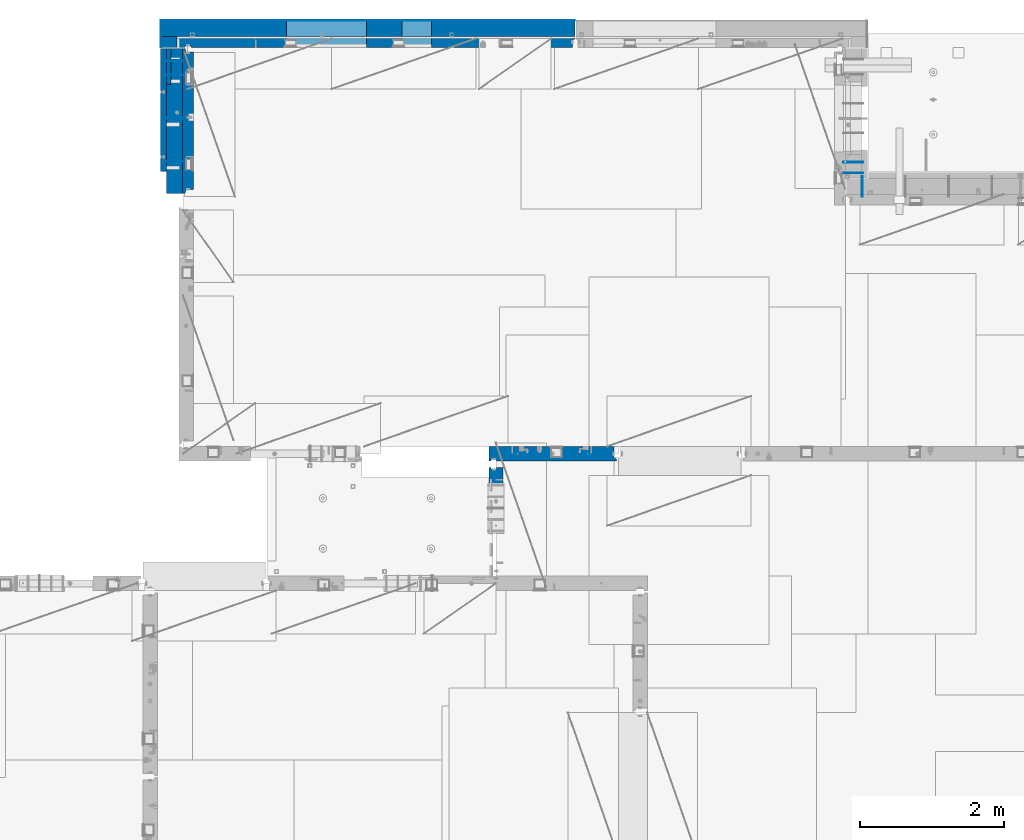
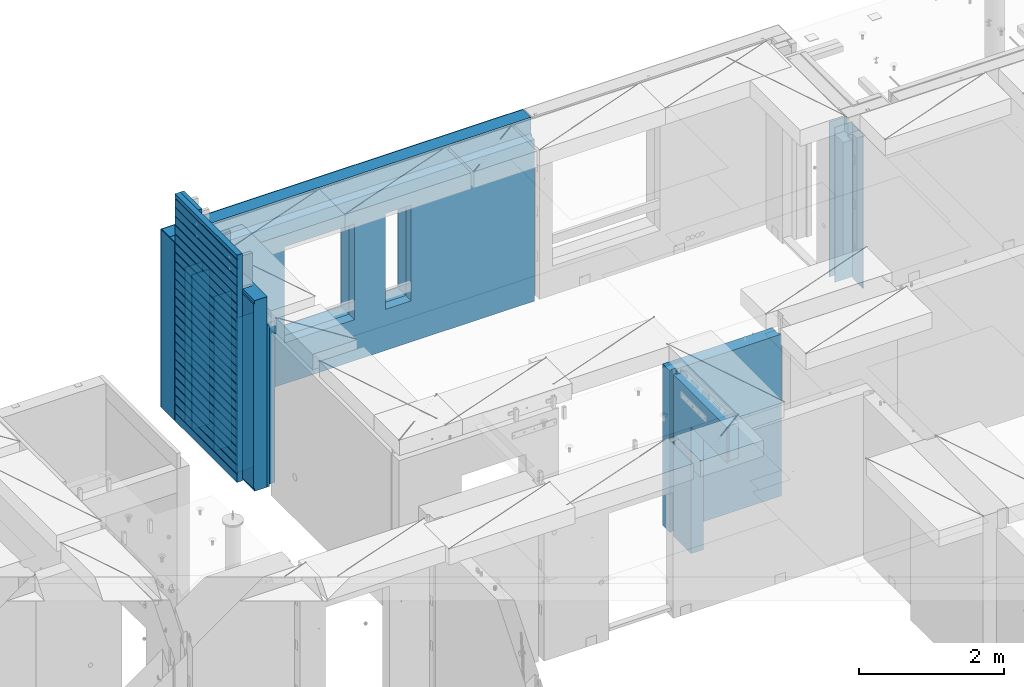
# One storey, part 204 of 309: 18 walls, 6 elements without a shape of their own.
"""IFC2X3 building model written with IfcOpenShell, lengths in millimetres."""

from ifc_helpers import new_model, si_unit, frame, origin_with_axes, place, context, subcontext, project, spatial, faceted_brep, material, type_object, element, aggregate, save


model = new_model("IFC2X3")

# Units and contexts
model_context = context("Model", 3, precision=1e-05, world=origin_with_axes())
body_context = subcontext(model_context, "Body", "Model", "MODEL_VIEW")
ifc_project = project(units=[si_unit("LENGTHUNIT", "METRE", prefix="MILLI"), si_unit("AREAUNIT", "SQUARE_METRE"), si_unit("VOLUMEUNIT", "CUBIC_METRE"), si_unit("MASSUNIT", "GRAM", prefix="KILO"), si_unit("TIMEUNIT", "SECOND"), si_unit("PLANEANGLEUNIT", "RADIAN"), si_unit("SOLIDANGLEUNIT", "STERADIAN"), si_unit("THERMODYNAMICTEMPERATUREUNIT", "DEGREE_CELSIUS"), si_unit("LUMINOUSINTENSITYUNIT", "LUMEN")], contexts=[model_context])

# Site, building, storey
site_placement = place(None, origin_with_axes())
site = spatial("IfcSite", under=ifc_project, at=site_placement, CompositionType="ELEMENT")
building_placement = place(site_placement, origin_with_axes())
building = spatial("IfcBuilding", under=site, at=building_placement, CompositionType="ELEMENT")
storey_placement = place(building_placement, origin_with_axes())
storey = spatial("IfcBuildingStorey", under=building, at=storey_placement, Name="7", CompositionType="ELEMENT", Elevation=0.0)

# Assembly, walls
assembly_1_placement = place(storey_placement, origin_with_axes())
assembly_1 = element("IfcElementAssembly", 1, at=assembly_1_placement, inside=storey, AssemblyPlace="NOTDEFINED", PredefinedType="REINFORCEMENT_UNIT")
ifc_material_1 = material(Name="Undefined")
wall_type_1 = type_object("IfcWallType", PredefinedType="NOTDEFINED")
wall_1_placement = place(assembly_1_placement, frame((22010.0, 21035.0, 101115.0), z_axis=(0.0, 0.0, 1.0), x_axis=(1.0, 0.0, 0.0)))
wall_1 = element("IfcWall", 2, at=wall_1_placement, type_object=wall_type_1, material=ifc_material_1, Name="(PD)", context=body_context, shape_type="Brep", body=[
    faceted_brep([(0.0, 5.0, -1300.0), (0.0, 5.0, 1300.0), (280.0, 5.0, 1300.0), (280.0, 5.0, -1300.0), (0.0, -5.0, 1300.0), (280.0, -5.0, 1300.0), (0.0, -5.0, -1300.0), (280.0, -5.0, -1300.0)], [[[0, 1, 2, 3]], [[1, 4, 5, 2]], [[4, 6, 7, 5]], [[6, 0, 3, 7]], [[5, 7, 3, 2]], [[6, 4, 1, 0]]]),
])
wall_2_placement = place(assembly_1_placement, frame((22010.0, 21635.0, 101115.0), z_axis=(0.0, 0.0, 1.0), x_axis=(1.0, 0.0, 0.0)))
wall_2 = element("IfcWall", 3, at=wall_2_placement, type_object=wall_type_1, material=ifc_material_1, Name="(PD)", context=body_context, shape_type="Brep", body=[
    faceted_brep([(0.0, 5.0, -1300.0), (0.0, 5.0, 1300.0), (280.0, 5.0, 1300.0), (280.0, 5.0, -1300.0), (0.0, -5.0, 1300.0), (280.0, -5.0, 1300.0), (0.0, -5.0, -1300.0), (280.0, -5.0, -1300.0)], [[[0, 1, 2, 3]], [[1, 4, 5, 2]], [[4, 6, 7, 5]], [[6, 0, 3, 7]], [[5, 7, 3, 2]], [[6, 4, 1, 0]]]),
])
wall_3_placement = place(assembly_1_placement, frame((22010.0, 22235.0, 101115.0), z_axis=(0.0, 0.0, 1.0), x_axis=(1.0, 0.0, 0.0)))
wall_3 = element("IfcWall", 4, at=wall_3_placement, type_object=wall_type_1, material=ifc_material_1, Name="(PD)", context=body_context, shape_type="Brep", body=[
    faceted_brep([(0.0, 5.0, -1300.0), (0.0, 5.0, 1300.0), (280.0, 5.0, 1300.0), (280.0, 5.0, -1300.0), (0.0, -5.0, 1300.0), (280.0, -5.0, 1300.0), (0.0, -5.0, -1300.0), (280.0, -5.0, -1300.0)], [[[0, 1, 2, 3]], [[1, 4, 5, 2]], [[4, 6, 7, 5]], [[6, 0, 3, 7]], [[5, 7, 3, 2]], [[6, 4, 1, 0]]]),
])
wall_4_placement = place(assembly_1_placement, frame((22010.0, 22435.0, 101115.0), z_axis=(0.0, 0.0, 1.0), x_axis=(1.0, 0.0, 0.0)))
wall_4 = element("IfcWall", 5, at=wall_4_placement, type_object=wall_type_1, material=ifc_material_1, Name="(PD)", context=body_context, shape_type="Brep", body=[
    faceted_brep([(0.0, 5.0, -1300.0), (0.0, 5.0, 1300.0), (280.0, 5.0, 1300.0), (280.0, 5.0, -1300.0), (0.0, -5.0, 1300.0), (280.0, -5.0, 1300.0), (0.0, -5.0, -1300.0), (280.0, -5.0, -1300.0)], [[[0, 1, 2, 3]], [[1, 4, 5, 2]], [[4, 6, 7, 5]], [[6, 0, 3, 7]], [[5, 7, 3, 2]], [[6, 4, 1, 0]]]),
])

# Assembly, wall
assembly_2_placement = place(storey_placement, origin_with_axes())
assembly_2 = element("IfcElementAssembly", 6, at=assembly_2_placement, inside=storey, AssemblyPlace="NOTDEFINED", PredefinedType="REINFORCEMENT_UNIT")
wall_5_placement = place(assembly_2_placement, frame((31695.0, 20549.9951872276, 101115.0), z_axis=(0.0, 0.0, 1.0), x_axis=(0.0, 1.0, 0.0)))
wall_5 = element("IfcWall", 7, at=wall_5_placement, type_object=wall_type_1, material=ifc_material_1, Name="(PD)", context=body_context, shape_type="Brep", body=[
    faceted_brep([(0.0, 5.0, -1300.0), (0.0, 5.0, 1300.0), (280.0, 5.0, 1300.0), (280.0, 5.0, -1300.0), (0.0, -5.0, 1300.0), (280.0, -5.0, 1300.0), (0.0, -5.0, -1300.0), (280.0, -5.0, -1300.0)], [[[0, 1, 2, 3]], [[1, 4, 5, 2]], [[4, 6, 7, 5]], [[6, 0, 3, 7]], [[5, 7, 3, 2]], [[6, 4, 1, 0]]]),
])
aggregate(assembly_2, [wall_5])

# Assembly, walls
assembly_3_placement = place(storey_placement, origin_with_axes())
assembly_3 = element("IfcElementAssembly", 8, at=assembly_3_placement, inside=storey, AssemblyPlace="NOTDEFINED", PredefinedType="REINFORCEMENT_UNIT")
wall_6_placement = place(assembly_3_placement, frame((31429.9951872276, 20875.0, 101115.0), z_axis=(0.0, 0.0, 1.0), x_axis=(1.0, 0.0, 0.0)))
wall_6 = element("IfcWall", 9, at=wall_6_placement, type_object=wall_type_1, material=ifc_material_1, Name="(PD)", context=body_context, shape_type="Brep", body=[
    faceted_brep([(0.0, 5.0, -1300.0), (0.0, 5.0, 1300.0), (280.0, 5.0, 1300.0), (280.0, 5.0, -1300.0), (0.0, -5.0, 1300.0), (280.0, -5.0, 1300.0), (0.0, -5.0, -1300.0), (280.0, -5.0, -1300.0)], [[[0, 1, 2, 3]], [[1, 4, 5, 2]], [[4, 6, 7, 5]], [[6, 0, 3, 7]], [[5, 7, 3, 2]], [[6, 4, 1, 0]]]),
])
wall_7_placement = place(assembly_3_placement, frame((31429.9951872276, 21025.0, 101115.0), z_axis=(0.0, 0.0, 1.0), x_axis=(1.0, 0.0, 0.0)))
wall_7 = element("IfcWall", 10, at=wall_7_placement, type_object=wall_type_1, material=ifc_material_1, Name="(PD)", context=body_context, shape_type="Brep", body=[
    faceted_brep([(0.0, 5.0, -1300.0), (0.0, 5.0, 1300.0), (280.0, 5.0, 1300.0), (280.0, 5.0, -1300.0), (0.0, -5.0, 1300.0), (280.0, -5.0, 1300.0), (0.0, -5.0, -1300.0), (280.0, -5.0, -1300.0)], [[[0, 1, 2, 3]], [[1, 4, 5, 2]], [[4, 6, 7, 5]], [[6, 0, 3, 7]], [[5, 7, 3, 2]], [[6, 4, 1, 0]]]),
])
aggregate(assembly_3, [wall_6, wall_7])

# Assembly, wall
assembly_4_placement = place(storey_placement, origin_with_axes())
assembly_4 = element("IfcElementAssembly", 11, at=assembly_4_placement, inside=storey, AssemblyPlace="NOTDEFINED", PredefinedType="REINFORCEMENT_UNIT")
ifc_material_2 = material(Name="CONCRETE/C25/30")
wall_type_2 = type_object("IfcWallType", PredefinedType="NOTDEFINED")
wall_8_placement = place(assembly_4_placement, frame((26510.0014364077, 16980.0, 101112.5), z_axis=(0.0, 0.0, 1.0), x_axis=(1.0, 0.0, 0.0)))
wall_8 = element("IfcWall", 12, at=wall_8_placement, type_object=wall_type_2, material=ifc_material_2, context=body_context, shape_type="Brep", body=[
    faceted_brep([(1739.99847412109, 100.0, 1357.5), (1739.99847412109, -57.0, 1357.5), (1739.99847412109, -57.0, -1357.5), (1739.99847412109, 100.0, -1357.5), (1769.99847412109, -70.0, 1357.5), (1769.99847412109, -70.0, -1357.5), (0.0, -100.0, -1357.5), (0.0, -100.0, 1357.5), (0.0, 100.0, 1357.5), (0.0, 100.0, -1357.5), (29.998563592264, -100.0, -1357.5), (29.998563592264, -100.0, 1357.5), (29.998563592264, -80.0008544921875, -1357.5), (29.998563592264, -80.0008544921875, 1357.5), (109.998563592264, -80.0008544921875, -1357.5), (109.998563592264, -80.0008544921875, 1357.5), (109.998563592264, -100.0, -1357.5), (109.998563592264, -100.0, 1357.5), (1769.99847412109, -100.0, -1357.5), (1769.99847412109, -100.0, 1357.5)], [[[0, 1, 2, 3]], [[4, 5, 2, 1]], [[6, 7, 8, 9]], [[7, 6, 10, 11]], [[11, 10, 12, 13]], [[13, 12, 14, 15]], [[15, 14, 16, 17]], [[18, 19, 17, 16]], [[0, 8, 7, 11, 13, 15, 17, 19, 4, 1]], [[9, 8, 0, 3]], [[18, 16, 14, 12, 10, 6, 9, 3, 2, 5]], [[19, 18, 5, 4]]]),
])
aggregate(assembly_4, [wall_8])

assembly_5_placement = place(storey_placement, origin_with_axes())
assembly_5 = element("IfcElementAssembly", 13, at=assembly_5_placement, inside=storey, AssemblyPlace="NOTDEFINED", PredefinedType="REINFORCEMENT_UNIT")
wall_9_placement = place(assembly_5_placement, frame((26609.9991475894, 15280.0004107749, 101112.5), z_axis=(0.0, 0.0, 1.0), x_axis=(0.0, 1.0, 0.0)))
wall_9 = element("IfcWall", 14, at=wall_9_placement, type_object=wall_type_2, material=ifc_material_2, context=body_context, shape_type="Brep", body=[
    faceted_brep([(1509.99949975397, 70.0, 1357.5), (1489.99949975397, 70.0, 1357.5), (1489.99949975397, 70.0, -1357.5), (1509.99949975397, 70.0, -1357.5), (1489.99949975397, -10.0, 1357.5), (1489.99949975397, -10.0, -1357.5), (1509.99949975397, -10.0, 1357.5), (1509.99949975397, -10.0, -1357.5), (29.9995892251427, 70.0, 1357.5), (29.9995892251427, 70.0, 762.5), (59.9995892251427, 57.0, 762.5), (59.9995892251427, 57.0, 1357.5), (29.9995892251427, 100.0, 1357.5), (29.9995892251427, 100.0, 762.5), (1509.99949975397, 100.0, 1357.5), (1509.99949975397, 100.0, -1357.5), (1019.99979369292, 100.0, -1357.5), (1019.99979369292, 100.0, 762.5), (1019.99979369292, -100.0, 762.5), (1019.99979369292, -100.0, -1357.5), (59.9995892251427, -100.0, 762.5), (59.9995892251427, -100.0, 1357.5), (1509.99949975397, -100.0, -1357.5), (1509.99949975397, -100.0, 1357.5)], [[[0, 1, 2, 3]], [[4, 5, 2, 1]], [[6, 7, 5, 4]], [[8, 9, 10, 11]], [[12, 13, 9, 8]], [[12, 14, 15, 16, 17, 13]], [[18, 17, 16, 19]], [[9, 13, 17, 18, 20, 10]], [[21, 11, 10, 20]], [[18, 19, 22, 23, 21, 20]], [[1, 0, 14, 12, 8, 11, 21, 23, 6, 4]], [[15, 14, 0, 3]], [[22, 19, 16, 15, 3, 2, 5, 7]], [[23, 22, 7, 6]]]),
])
aggregate(assembly_5, [wall_9])

# Assembly, walls
assembly_6_placement = place(storey_placement, origin_with_axes())
assembly_6 = element("IfcElementAssembly", 15, at=assembly_6_placement, inside=storey, AssemblyPlace="NOTDEFINED", PredefinedType="REINFORCEMENT_UNIT")
ifc_material_3 = material()
wall_type_3 = type_object("IfcWallType", PredefinedType="NOTDEFINED")
wall_10_placement = place(assembly_6_placement, frame((22075.0, 22620.0, 101247.5), z_axis=(0.0, 0.0, 1.0), x_axis=(0.0, 1.0, 0.0)))
wall_10 = element("IfcWall", 16, at=wall_10_placement, type_object=wall_type_3, material=ifc_material_3, context=body_context, shape_type="Brep", body=[
    faceted_brep([(0.0, 110.0, -1492.5), (0.0, 110.0, 1492.5), (150.0, 110.0, 1492.5), (150.0, 110.0, -1492.5), (0.0, -110.0, 1492.5), (150.0, -110.0, 1492.5), (0.0, -110.0, -1492.5), (150.0, -110.0, -1492.5)], [[[0, 1, 2, 3]], [[1, 4, 5, 2]], [[4, 6, 7, 5]], [[6, 0, 3, 7]], [[5, 7, 3, 2]], [[6, 4, 1, 0]]]),
])
wall_11_placement = place(assembly_6_placement, frame((22260.0, 22880.0, 101247.5), z_axis=(0.0, 0.0, 1.0), x_axis=(1.0, 0.0, 0.0)))
wall_11 = element("IfcWall", 17, at=wall_11_placement, type_object=wall_type_3, material=ifc_material_3, context=body_context, shape_type="Brep", body=[
    faceted_brep([(-295.0, 110.0, 1492.5), (-295.0, -110.0, 1492.5), (5445.0, -110.0, 1492.5), (5445.0, 110.0, 1492.5), (-295.0, -110.0, -1492.5), (-295.0, 110.0, -1492.5), (5445.0, 110.0, -1492.5), (5445.0, -110.0, -1492.5), (3044.99635379813, 110.0, -802.5), (3454.99635379813, 110.0, -802.5), (3454.99635379813, 110.0, 807.5), (3044.99635379813, 110.0, 807.5), (1444.99910133321, 110.0, -802.5), (2554.99910133321, 110.0, -802.5), (2554.99910133321, 110.0, 807.5), (1444.99910133321, 110.0, 807.5), (1444.99910133321, -110.0, -802.5), (2554.99910133321, -110.0, -802.5), (1444.99910133321, -110.0, 807.5), (2554.99910133321, -110.0, 807.5), (3044.99635379813, -110.0, -802.5), (3044.99635379813, -110.0, 807.5), (3454.99635379813, -110.0, 807.5), (3454.99635379813, -110.0, -802.5)], [[[0, 1, 2, 3]], [[4, 1, 0, 5]], [[4, 5, 6, 7]], [[2, 7, 6, 3]], [[5, 0, 3, 6], [8, 9, 10, 11], [12, 13, 14, 15]], [[12, 16, 17, 13]], [[15, 18, 16, 12]], [[14, 19, 18, 15]], [[13, 17, 19, 14]], [[1, 4, 7, 2], [20, 21, 22, 23], [16, 18, 19, 17]], [[10, 22, 21, 11]], [[9, 23, 22, 10]], [[8, 20, 23, 9]], [[11, 21, 20, 8]]]),
])
wall_type_4 = type_object("IfcWallType", PredefinedType="NOTDEFINED")
wall_12_placement = place(assembly_6_placement, frame((22192.5, 22695.0, 101112.5), z_axis=(0.0, 0.0, 1.0), x_axis=(1.0, 0.0, 0.0)))
wall_12 = element("IfcWall", 18, at=wall_12_placement, type_object=wall_type_4, material=ifc_material_2, context=body_context, shape_type="Brep", body=[
    faceted_brep([(3112.49635379813, 75.0, 942.5), (3112.49635379813, -75.0000009061441, 942.5), (3112.49635379813, -75.0000002303786, -667.5), (3112.49635379813, 75.0, -667.5), (3522.49635379813, -75.0000001420558, -667.5), (3522.49635379813, 75.0, -667.5), (3522.49635379813, -75.0000008178213, 942.5), (3522.49635379813, 75.0, 942.5), (5482.5, -75.0, 1357.5), (5482.5, -75.0, -1357.5), (5482.5, 24.9999980926514, -1357.5), (5482.5, 24.9999980926514, 1357.5), (5512.5, 45.0, 1357.5), (5512.5, 75.0, 1357.5), (0.0, 75.0, 1357.5), (0.0, -75.0, 1357.5), (92.5, -75.0, 1357.5), (102.5, -55.0000022791319, 1357.5), (182.5, -55.0000022791319, 1357.5), (192.5, -75.0000022791319, 1357.5), (0.0, -75.0, -1357.5), (0.0, 75.0, -1357.5), (92.5, -75.0, -1357.5), (102.5, -55.0000022791319, -1357.5), (182.5, -55.0000022791319, -1357.5), (192.5, -75.0, -1357.5), (5512.5, 75.0, -1357.5), (5512.5, 45.0, -1357.5), (1512.49910133321, 75.0, -667.5), (2622.49910133321, 75.0, -667.5), (2622.49910133321, 75.0, 942.5), (1512.49910133321, 75.0, 942.5), (1512.49910133321, -75.000000575048, -667.5), (2622.49910133321, -75.000000335931, -667.5), (1512.49910133321, -75.0000012508135, 942.5), (2622.49910133321, -75.0000010116964, 942.5)], [[[0, 1, 2, 3]], [[3, 2, 4, 5]], [[5, 4, 6, 7]], [[7, 6, 1, 0]], [[8, 9, 10, 11]], [[8, 11, 12, 13, 14, 15, 16, 17, 18, 19]], [[20, 15, 14, 21]], [[15, 20, 22, 16]], [[16, 22, 23, 17]], [[17, 23, 24, 18]], [[19, 18, 24, 25]], [[23, 22, 20, 21, 26, 27, 10, 9, 25, 24]], [[12, 11, 10, 27]], [[26, 13, 12, 27]], [[21, 14, 13, 26], [3, 5, 7, 0], [28, 29, 30, 31]], [[28, 32, 33, 29]], [[31, 34, 32, 28]], [[30, 35, 34, 31]], [[29, 33, 35, 30]], [[9, 8, 19, 25], [2, 1, 6, 4], [32, 34, 35, 33]]]),
])

# Wall
wall_13_placement = place(assembly_1_placement, frame((22335.0, 20595.0, 101112.5), z_axis=(0.0, 0.0, 1.0), x_axis=(0.0, 1.0, 0.0)))
wall_13 = element("IfcWall", 19, at=wall_13_placement, type_object=wall_type_4, material=ifc_material_2, context=body_context, shape_type="Brep", body=[
    faceted_brep([(0.0, 40.0, 1357.5), (0.0, 40.0, -1357.5), (50.0, 27.0, -1357.5), (50.0, 27.0, 1357.5), (50.0, -75.0, 1357.5), (50.0, -75.0, -1357.5), (0.0, 75.0, -1357.5), (0.0, 75.0, 1357.5), (2009.99999772087, 75.0, 1357.5), (2009.99999772087, 75.0, -1357.5), (2009.99999772087, 40.0, 1357.5), (2009.99999772087, 40.0, -1357.5), (1959.99999772087, 27.0, 1357.5), (1959.99999772087, 27.0, -1357.5), (1959.99999772087, -75.0, 1357.5), (1959.99999772087, -75.0, -1357.5)], [[[0, 1, 2, 3]], [[4, 3, 2, 5]], [[6, 7, 8, 9]], [[9, 8, 10, 11]], [[12, 13, 11, 10]], [[14, 15, 13, 12]], [[15, 14, 4, 5]], [[1, 6, 9, 11, 13, 15, 5, 2]], [[7, 6, 1, 0]], [[14, 12, 10, 8, 7, 0, 3, 4]]]),
])

ifc_material_4 = material(Name="CONCRETE/C30/37")
wall_type_5 = type_object("IfcWallType", PredefinedType="NOTDEFINED")
wall_14_placement = place(assembly_6_placement, frame((21960.0001313636, 22620.0, 101247.5), z_axis=(0.0, 0.0, 1.0), x_axis=(0.0, 1.0, 0.0)))
wall_14 = element("IfcWall", 20, at=wall_14_placement, type_object=wall_type_5, material=ifc_material_4, context=body_context, shape_type="Brep", body=[
    faceted_brep([(0.0, 5.0, -1492.5), (0.0, 5.0, 1492.5), (370.0, 5.0, 1492.5), (370.0, 5.0, -1492.5), (0.0, -5.0, 1492.5), (370.0, -5.0, 1492.5), (0.0, -5.0, -1492.5), (370.0, -5.0, -1492.5)], [[[0, 1, 2, 3]], [[1, 4, 5, 2]], [[4, 6, 7, 5]], [[6, 0, 3, 7]], [[5, 7, 3, 2]], [[6, 4, 1, 0]]]),
])

wall_15_placement = place(assembly_6_placement, frame((22260.0, 22995.0, 101247.5), z_axis=(0.0, 0.0, 1.0), x_axis=(1.0, 0.0, 0.0)))
wall_15 = element("IfcWall", 21, at=wall_15_placement, type_object=wall_type_5, material=ifc_material_4, context=body_context, shape_type="Brep", body=[
    faceted_brep([(-305.0, 5.0, 1492.5), (-305.0, -5.0, 1492.5), (5445.0, -5.0, 1492.5), (5445.0, 5.0, 1492.5), (-305.0, -5.0, -1492.5), (-305.0, 5.0, -1492.5), (5445.0, 5.0, -1492.5), (5445.0, -5.0, -1492.5), (3044.99635379813, 5.0, -802.5), (3454.99635379813, 5.0, -802.5), (3454.99635379813, 5.0, 807.5), (3044.99635379813, 5.0, 807.5), (1444.99910133321, 5.0, -802.5), (2554.99910133321, 5.0, -802.5), (2554.99910133321, 5.0, 807.5), (1444.99910133321, 5.0, 807.5), (1444.99910133321, -5.0, -802.5), (2554.99910133321, -5.0, -802.5), (1444.99910133321, -5.0, 807.5), (2554.99910133321, -5.0, 807.5), (3044.99635379813, -5.0, -802.5), (3044.99635379813, -5.0, 807.5), (3454.99635379813, -5.0, 807.5), (3454.99635379813, -5.0, -802.5)], [[[0, 1, 2, 3]], [[4, 1, 0, 5]], [[4, 5, 6, 7]], [[2, 7, 6, 3]], [[5, 0, 3, 6], [8, 9, 10, 11], [12, 13, 14, 15]], [[12, 16, 17, 13]], [[15, 18, 16, 12]], [[14, 19, 18, 15]], [[13, 17, 19, 14]], [[1, 4, 7, 2], [20, 21, 22, 23], [16, 18, 19, 17]], [[10, 22, 21, 11]], [[9, 23, 22, 10]], [[8, 20, 23, 9]], [[11, 21, 20, 8]]]),
])

aggregate(assembly_6, [wall_14, wall_10, wall_11, wall_15, wall_12])

wall_type_6 = type_object("IfcWallType", PredefinedType="NOTDEFINED")
wall_16_placement = place(assembly_1_placement, frame((21997.5, 20900.0, 101662.5), z_axis=(0.0, 0.0, 1.0), x_axis=(0.0, 1.0, 0.0)))
wall_16 = element("IfcWall", 22, at=wall_16_placement, type_object=wall_type_6, material=ifc_material_4, context=body_context, shape_type="Brep", body=[
    faceted_brep([(1705.0, 42.5, 1828.0), (0.0, 42.5, 1828.0), (0.0, 32.5, 1830.0), (1705.0, 32.5, 1830.0), (1705.0, 32.5, 1840.0), (0.0, 32.5, 1840.0), (0.0, 42.5, 1842.0), (1705.0, 42.5, 1842.0), (1705.0, 32.5, 1690.0), (0.0, 32.5, 1690.0), (0.0, 42.5, 1692.0), (1705.0, 42.5, 1692.0), (1705.0, 32.5, 1680.0), (0.0, 32.5, 1680.0), (1705.0, 42.5, 1678.0), (0.0, 42.5, 1678.0), (1705.0, 42.5, 1542.0), (0.0, 42.5, 1542.0), (1705.0, 32.5, 1540.0), (0.0, 32.5, 1540.0), (1705.0, 32.5, 1530.0), (0.0, 32.5, 1530.0), (1705.0, 42.5, 1528.0), (0.0, 42.5, 1528.0), (1705.0, 42.5, 1392.0), (0.0, 42.5, 1392.0), (1705.0, 32.5, 1390.0), (0.0, 32.5, 1390.0), (1705.0, 32.5, 1380.0), (0.0, 32.4999991119257, 1380.00000040043), (1705.0, 42.5, 1378.0), (0.0, 42.5, 1378.0), (1705.0, 42.5, 1242.0), (0.0, 42.5, 1242.0), (1705.0, 32.5, 1240.0), (0.0, 32.5, 1240.0), (1705.0, 32.5, 1230.0), (0.0, 32.4999991119257, 1230.00000040043), (1705.0, 42.5, 1228.0), (0.0, 42.5, 1228.0), (1705.0, 42.5, 1092.0), (0.0, 42.5, 1092.0), (1705.0, 32.5, 1090.0), (0.0, 32.5, 1090.0), (1705.0, 32.5, 1080.0), (0.0, 32.4999991119257, 1080.00000040043), (1705.0, 42.5, 1078.0), (0.0, 42.5, 1078.0), (1705.0, 42.5, 942.0), (0.0, 42.5, 942.0), (1705.0, 32.5, 940.0), (0.0, 32.5, 940.0), (1705.0, 32.5, 930.0), (0.0, 32.4999991119257, 930.000000400425), (1705.0, 42.5, 928.0), (0.0, 42.5, 928.0), (1705.0, 42.5, 792.0), (0.0, 42.5, 792.0), (1705.0, 32.5, 790.0), (0.0, 32.5, 790.0), (1705.0, 32.5, 780.0), (0.0, 32.4999992501716, 779.999999999243), (1705.0, 42.5, 778.0), (0.0, 42.5, 777.999999944761), (1705.0, 42.5, 642.0), (0.0, 42.5, 642.0), (1705.0, 32.5, 640.0), (0.0, 32.5, 640.0), (1705.0, 32.5, 630.0), (0.0, 32.4999991119257, 630.000000400425), (1705.0, 42.5, 628.0), (0.0, 42.5, 628.0), (1705.0, 42.5, 492.0), (0.0, 42.5, 491.999999889245), (1705.0, 32.5, 490.0), (0.0, 32.4999991121731, 490.00000040044), (1705.0, 32.5, 480.0), (0.0, 32.4999992501716, 479.999999999243), (1705.0, 42.5, 478.0), (0.0, 42.5, 477.999999944761), (1705.0, 42.5, 342.0), (0.0, 42.5, 342.0), (1705.0, 32.5, 340.0), (0.0, 32.5, 340.0), (1705.0, 32.5, 330.0), (0.0, 32.4999991119257, 330.000000400425), (1705.0, 42.5, 328.0), (0.0, 42.5, 328.0), (1705.0, 42.5, 192.0), (0.0, 42.5, 191.999999889245), (1705.0, 32.5, 190.0), (0.0, 32.4999991121731, 190.00000040044), (1705.0, 32.5, 180.0), (0.0, 32.4999992501716, 179.999999999243), (1705.0, 42.5, 178.0), (0.0, 42.5, 177.999999944761), (1705.0, 42.5, 42.0), (0.0, 42.5, 42.0), (1705.0, 32.5, 40.0), (0.0, 32.5, 40.0), (1705.0, 32.5, 30.0), (1.81898940354586e-12, 32.4999991119257, 30.0000004004251), (1705.0, 42.5, 28.0), (0.0, 42.5, 28.0), (1705.0, 42.5, -108.0), (0.0, 42.5, -108.000000110755), (1705.0, 32.5, -110.0), (0.0, 32.4999991121731, -109.99999959956), (1705.0, 32.5, -120.0), (0.0, 32.4999992501716, -120.000000000757), (1705.0, 42.5, -122.0), (0.0, 42.5, -122.000000055239), (1705.0, 42.5, -258.0), (0.0, 42.5, -258.0), (1705.0, 32.5, -260.0), (0.0, 32.5, -260.0), (1705.0, 32.5, -270.0), (0.0, 32.4999991119257, -269.999999599575), (1705.0, 42.5, -272.0), (0.0, 42.5, -272.0), (1705.0, 42.5, -408.0), (0.0, 42.5, -408.000000110755), (1705.0, 32.5, -410.0), (0.0, 32.4999991121731, -409.99999959956), (1705.0, 32.5, -420.0), (0.0, 32.4999992501716, -420.000000000757), (1705.0, 42.5, -422.0), (0.0, 42.5, -422.000000055239), (1705.0, 42.5, -558.0), (0.0, 42.5, -558.0), (1705.0, 32.5, -560.0), (0.0, 32.5, -560.0), (1705.0, 32.5, -570.0), (0.0, 32.4999991119257, -569.999999599575), (1705.0, 42.5, -572.0), (0.0, 42.5, -572.0), (1705.0, 42.5, -708.0), (0.0, 42.5, -708.000000110755), (1705.0, 32.5, -710.0), (0.0, 32.4999991121731, -709.99999959956), (1705.0, 32.5, -720.0), (0.0, 32.4999992501716, -720.000000000757), (1705.0, 42.5, -722.0), (0.0, 42.5, -722.000000055239), (1705.0, 42.5, -858.0), (0.0, 42.5, -858.0), (1705.0, 32.5, -860.0), (0.0, 32.5, -860.0), (1705.0, 32.5, -870.0), (0.0, 32.4999991119257, -869.999999599575), (1705.0, 42.5, -872.0), (0.0, 42.5, -872.0), (1705.0, 42.5, -1008.0), (0.0, 42.5, -1008.00000011075), (1705.0, 32.5, -1010.0), (0.0, 32.4999991121731, -1009.99999959956), (1705.0, 32.5, -1020.0), (0.0, 32.4999992501716, -1020.00000000076), (1705.0, 42.5, -1022.0), (0.0, 42.5, -1022.00000005524), (1705.0, 42.5, -1158.0), (0.0, 42.5, -1158.0), (1705.0, 32.5, -1160.0), (0.0, 32.5, -1160.0), (1705.0, 32.5, -1170.0), (0.0, 32.5, -1170.0), (1705.0, 42.5, -1172.0), (0.0, 42.5, -1172.0), (1705.0, 42.5, -1308.0), (0.0, 42.5, -1308.00000011075), (1705.0, 32.5, -1310.0), (0.0, 32.4999991121731, -1309.99999959956), (1705.0, 32.5, -1320.0), (0.0, 32.4999992501716, -1320.00000000076), (1705.0, 42.5, -1322.0), (0.0, 42.5, -1322.00000005524), (1705.0, 42.5, -1458.0), (0.0, 42.5, -1458.0), (1705.0, 32.5, -1460.0), (0.0, 32.5, -1460.0), (1705.0, 32.5, -1470.0), (0.0, 32.5, -1470.0), (1705.0, 42.5, -1472.0), (0.0, 42.5, -1472.0), (1705.0, 42.5, -1608.0), (0.0, 42.5, -1608.00000011075), (1705.0, 32.5, -1610.0), (0.0, 32.4999991121731, -1609.99999959956), (1705.0, 32.5, -1620.0), (0.0, 32.4999992501716, -1620.00000000076), (1705.0, 42.5, -1622.0), (0.0, 42.5, -1622.00000005524), (1705.0, 42.5, -1758.0), (0.0, 42.5, -1758.0), (1705.0, 32.5, -1760.0), (0.0, 32.5, -1760.0), (1705.0, 32.5, -1770.0), (0.0, 32.5, -1770.0), (1705.0, 42.5, -1772.0), (0.0, 42.5, -1772.0), (1705.0, 42.5, -1907.5), (0.0, 42.5, -1907.5), (0.0, -42.5, -1907.5), (1705.0, -42.5, -1907.5), (0.0, -42.5, 1907.5), (1705.0, -42.5, 1907.5), (0.0, 42.5, 1907.5), (1705.0, 42.5, 1907.5)], [[[0, 1, 2, 3]], [[4, 5, 6, 7]], [[3, 2, 5, 4]], [[8, 9, 10, 11]], [[12, 13, 9, 8]], [[14, 15, 13, 12]], [[16, 17, 15, 14]], [[18, 19, 17, 16]], [[20, 21, 19, 18]], [[22, 23, 21, 20]], [[24, 25, 23, 22]], [[26, 27, 25, 24]], [[28, 29, 27, 26]], [[30, 31, 29, 28]], [[32, 33, 31, 30]], [[34, 35, 33, 32]], [[36, 37, 35, 34]], [[38, 39, 37, 36]], [[40, 41, 39, 38]], [[42, 43, 41, 40]], [[44, 45, 43, 42]], [[46, 47, 45, 44]], [[48, 49, 47, 46]], [[50, 51, 49, 48]], [[52, 53, 51, 50]], [[54, 55, 53, 52]], [[56, 57, 55, 54]], [[58, 59, 57, 56]], [[60, 61, 59, 58]], [[62, 63, 61, 60]], [[64, 65, 63, 62]], [[66, 67, 65, 64]], [[68, 69, 67, 66]], [[70, 71, 69, 68]], [[72, 73, 71, 70]], [[74, 75, 73, 72]], [[76, 77, 75, 74]], [[78, 79, 77, 76]], [[80, 81, 79, 78]], [[82, 83, 81, 80]], [[84, 85, 83, 82]], [[86, 87, 85, 84]], [[88, 89, 87, 86]], [[90, 91, 89, 88]], [[92, 93, 91, 90]], [[94, 95, 93, 92]], [[96, 97, 95, 94]], [[98, 99, 97, 96]], [[100, 101, 99, 98]], [[102, 103, 101, 100]], [[104, 105, 103, 102]], [[106, 107, 105, 104]], [[108, 109, 107, 106]], [[110, 111, 109, 108]], [[112, 113, 111, 110]], [[114, 115, 113, 112]], [[116, 117, 115, 114]], [[118, 119, 117, 116]], [[120, 121, 119, 118]], [[122, 123, 121, 120]], [[124, 125, 123, 122]], [[126, 127, 125, 124]], [[128, 129, 127, 126]], [[130, 131, 129, 128]], [[132, 133, 131, 130]], [[134, 135, 133, 132]], [[136, 137, 135, 134]], [[138, 139, 137, 136]], [[140, 141, 139, 138]], [[142, 143, 141, 140]], [[144, 145, 143, 142]], [[146, 147, 145, 144]], [[148, 149, 147, 146]], [[150, 151, 149, 148]], [[152, 153, 151, 150]], [[154, 155, 153, 152]], [[156, 157, 155, 154]], [[158, 159, 157, 156]], [[160, 161, 159, 158]], [[162, 163, 161, 160]], [[164, 165, 163, 162]], [[166, 167, 165, 164]], [[168, 169, 167, 166]], [[170, 171, 169, 168]], [[172, 173, 171, 170]], [[174, 175, 173, 172]], [[176, 177, 175, 174]], [[178, 179, 177, 176]], [[180, 181, 179, 178]], [[182, 183, 181, 180]], [[184, 185, 183, 182]], [[186, 187, 185, 184]], [[188, 189, 187, 186]], [[190, 191, 189, 188]], [[192, 193, 191, 190]], [[194, 195, 193, 192]], [[196, 197, 195, 194]], [[198, 199, 197, 196]], [[200, 201, 199, 198]], [[202, 201, 200, 203]], [[204, 202, 203, 205]], [[206, 204, 205, 207]], [[206, 207, 7, 6]], [[1, 10, 9, 13, 15, 17, 19, 21, 23, 25, 27, 29, 31, 33, 35, 37, 39, 41, 43, 45, 47, 49, 51, 53, 55, 57, 59, 61, 63, 65, 67, 69, 71, 73, 75, 77, 79, 81, 83, 85, 87, 89, 91, 93, 95, 97, 99, 101, 103, 105, 107, 109, 111, 113, 115, 117, 119, 121, 123, 125, 127, 129, 131, 133, 135, 137, 139, 141, 143, 145, 147, 149, 151, 153, 155, 157, 159, 161, 163, 165, 167, 169, 171, 173, 175, 177, 179, 181, 183, 185, 187, 189, 191, 193, 195, 197, 199, 201, 202, 204, 206, 6, 5, 2]], [[11, 10, 1, 0]], [[207, 205, 203, 200, 198, 196, 194, 192, 190, 188, 186, 184, 182, 180, 178, 176, 174, 172, 170, 168, 166, 164, 162, 160, 158, 156, 154, 152, 150, 148, 146, 144, 142, 140, 138, 136, 134, 132, 130, 128, 126, 124, 122, 120, 118, 116, 114, 112, 110, 108, 106, 104, 102, 100, 98, 96, 94, 92, 90, 88, 86, 84, 82, 80, 78, 76, 74, 72, 70, 68, 66, 64, 62, 60, 58, 56, 54, 52, 50, 48, 46, 44, 42, 40, 38, 36, 34, 32, 30, 28, 26, 24, 22, 20, 18, 16, 14, 12, 8, 11, 0, 3, 4, 7]]]),
])

wall_type_7 = type_object("IfcWallType", PredefinedType="NOTDEFINED")
wall_17_placement = place(assembly_1_placement, frame((22070.0, 22605.0, 101662.5), z_axis=(0.0, 0.0, 1.0), x_axis=(0.0, -1.0, 0.0)))
wall_17 = element("IfcWall", 23, at=wall_17_placement, type_object=wall_type_7, material=ifc_material_4, context=body_context, shape_type="Brep", body=[
    faceted_brep([(0.0, 30.0, -1907.5), (0.0, 30.0, 1907.5), (500.0, 30.0, 1907.5), (500.0, 30.0, -1907.5), (0.0, -30.0, 1907.5), (500.0, -30.0, 1907.5), (0.0, -30.0, -1907.5), (500.0, -30.0, -1907.5)], [[[0, 1, 2, 3]], [[1, 4, 5, 2]], [[4, 6, 7, 5]], [[6, 0, 3, 7]], [[5, 7, 3, 2]], [[6, 4, 1, 0]]]),
])

ifc_material_5 = material(Name="COS5gt")
wall_type_8 = type_object("IfcWallType", PredefinedType="NOTDEFINED")
wall_18_placement = place(assembly_1_placement, frame((22150.0, 20595.0, 101355.0), z_axis=(0.0, 0.0, 1.0), x_axis=(0.0, 1.0, 0.0)))
wall_18 = element("IfcWall", 24, at=wall_18_placement, type_object=wall_type_8, material=ifc_material_5, context=body_context, shape_type="Brep", body=[
    faceted_brep([(1510.0, 50.0, 1600.0), (1510.0, 50.0, -1600.0), (1510.0, 90.0, -1600.0), (1510.0, 90.0, -1550.0), (1510.0, 110.0, -1550.0), (1510.0, 110.0, 1550.0), (1510.0, 90.0, 1550.0), (1510.0, 90.0, 1600.0), (2010.0, 50.0, 1600.0), (2010.0, 50.0, -1600.0), (1530.0, 50.0, 1600.0), (1530.0, 50.0, 455.0), (1580.0, 50.0, 455.0), (1580.0, 50.0, 1600.0), (1835.0, 50.0, 1600.0), (1835.0, 50.0, 455.0), (1885.0, 50.0, 455.0), (1885.0, 50.0, 1600.0), (1885.0, -75.0, 1600.0), (1885.0, -75.0, 455.0), (1835.0, -75.0, 455.0), (1835.0, -75.0, 1600.0), (1580.0, -75.0, 1600.0), (1580.0, -75.0, 455.0), (1530.0, -75.0, 455.0), (1530.0, -75.0, 1600.0), (980.0, -65.0, 1600.0), (980.0, -65.0, 455.0), (930.0, -65.0, 455.0), (930.0, -65.0, 1600.0), (980.0, 90.0, 1600.0), (980.0, 90.0, 1550.0), (980.0, 110.0, 1550.0), (980.0, 110.0, 455.0), (930.0, 110.0, 455.0), (930.0, 90.0, 1600.0), (930.0, 90.0, 1550.0), (380.0, 90.0, 1550.0), (380.0, 90.0, 1600.0), (930.0, 110.0, 1550.0), (380.0, 110.0, 1550.0), (380.0, -65.0, 1600.0), (380.0, -65.0, 455.0), (330.0, -65.0, 455.0), (330.0, -65.0, 1600.0), (380.0, 110.0, 455.0), (330.0, 110.0, 455.0), (0.0, 90.0, 1550.0), (0.0, 90.0, 1600.0), (330.0, 90.0, 1600.0), (330.0, 90.0, 1550.0), (330.0, 110.0, 1550.0), (0.0, 110.0, 1550.0), (0.0, -110.0, -1600.0), (0.0, -110.0, 1600.0), (0.0, 110.0, -1550.0), (0.0, 90.0, -1550.0), (0.0, 90.0, -1600.0), (2010.0, -110.0, -1600.0), (2010.0, -110.0, 1600.0)], [[[0, 1, 2, 3, 4, 5, 6, 7]], [[8, 9, 1, 0, 10, 11, 12, 13, 14, 15, 16, 17]], [[18, 19, 20, 21]], [[19, 18, 17, 16]], [[20, 19, 16, 15]], [[21, 20, 15, 14]], [[22, 23, 24, 25]], [[23, 22, 13, 12]], [[24, 23, 12, 11]], [[25, 24, 11, 10]], [[26, 27, 28, 29]], [[30, 31, 32, 33, 27, 26]], [[34, 28, 27, 33]], [[35, 36, 37, 38]], [[29, 28, 34, 39, 36, 35]], [[36, 39, 40, 37]], [[41, 42, 43, 44]], [[38, 37, 40, 45, 42, 41]], [[46, 43, 42, 45]], [[47, 48, 49, 50]], [[44, 43, 46, 51, 50, 49]], [[52, 47, 50, 51]], [[53, 54, 48, 47, 52, 55, 56, 57]], [[54, 53, 58, 59]], [[18, 21, 14, 13, 22, 25, 10, 0, 7, 30, 26, 29, 35, 38, 41, 44, 49, 48, 54, 59, 8, 17]], [[31, 30, 7, 6]], [[32, 31, 6, 5]], [[55, 52, 51, 46, 45, 40, 39, 34, 33, 32, 5, 4]], [[56, 55, 4, 3]], [[57, 56, 3, 2]], [[58, 53, 57, 2, 1, 9]], [[59, 58, 9, 8]]]),
])

aggregate(assembly_1, [wall_1, wall_2, wall_3, wall_4, wall_17, wall_18, wall_16, wall_13])

save(model, "model.ifc")
